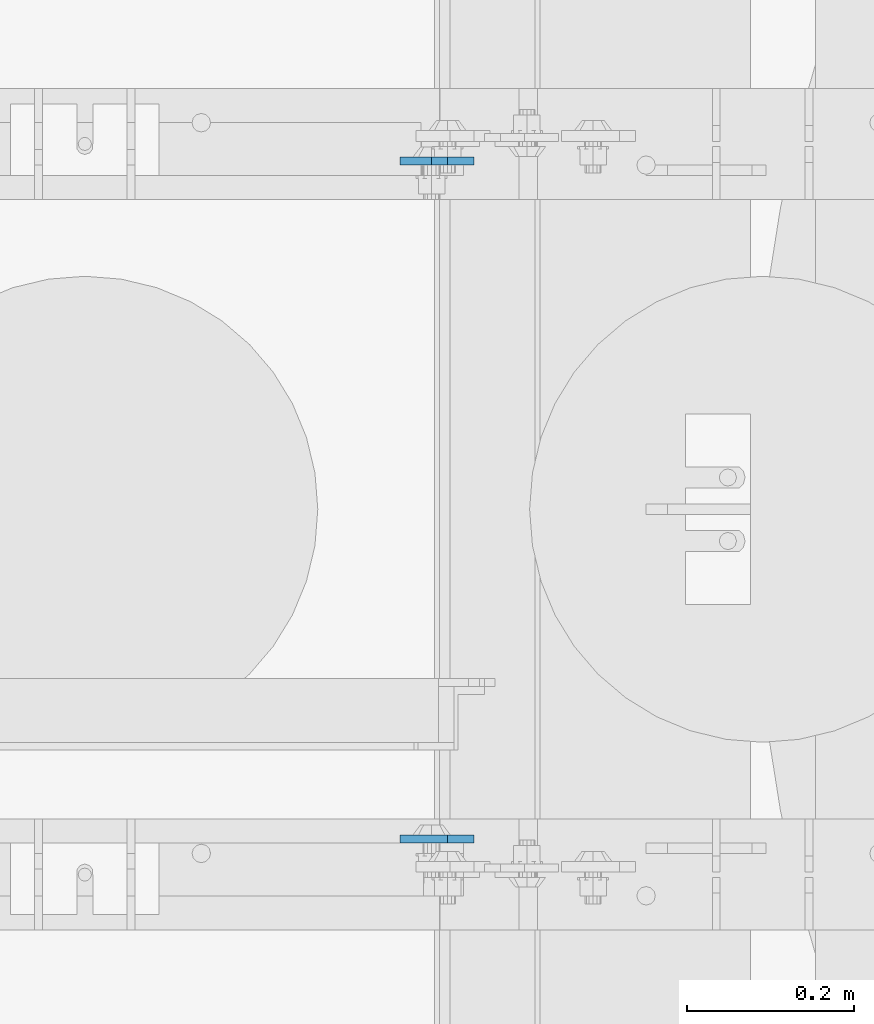
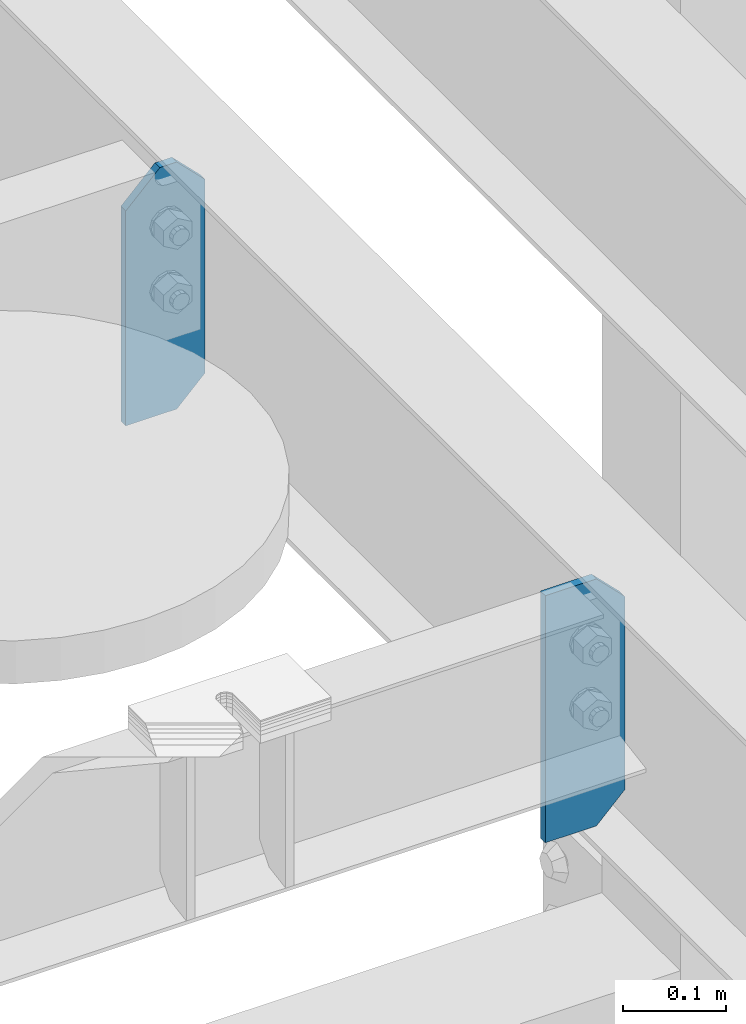
# One storey, part 1759 of 1876: 2 plates, 1 element without a shape of its own.
"""IFC2X3 building model written with IfcOpenShell, lengths in millimetres."""

import ifcopenshell
import ifcopenshell.guid

model = None  # the IFC model being written
_history = None  # IfcOwnerHistory: only IFC2X3 demands one
_inside = {}  # id of a spatial element -> (the spatial element, [elements in it])
_under = {}  # id of a project, library or spatial element -> (it, [spatial elements below it])
_declared = {}  # id of a project -> (the project, [libraries it declares])
_typed = {}  # id of a type object -> (the type object, [elements of that type])
_made_of = {}  # id of a material, layer set ... -> (it, [elements and type objects made of it])


def new_model(schema):
    """Start an empty IFC model of exactly this schema.

    Asked for "IFC4X3", IfcOpenShell would pick the latest addendum, in which some entities
    have other attributes; the version numbers below select the first issue.
    IFC2X3 requires an IfcOwnerHistory on every rooted entity: one is made here for all.
    """
    global model, _history
    if schema == "IFC4X3":
        model = ifcopenshell.file(schema_version=(4, 3, 0, 0))
    else:
        model = ifcopenshell.file(schema=schema)
    _inside.clear()
    _under.clear()
    _declared.clear()
    _typed.clear()
    _made_of.clear()
    _history = None
    if model.schema == "IFC2X3":
        org = make("IfcOrganization", Name="unknown")
        user = make(
            "IfcPersonAndOrganization",
            ThePerson=make("IfcPerson", FamilyName="unknown"),
            TheOrganization=org,
        )
        app = make(
            "IfcApplication",
            ApplicationDeveloper=org,
            Version="unknown",
            ApplicationFullName="unknown",
            ApplicationIdentifier="unknown",
        )
        _history = make(
            "IfcOwnerHistory",
            OwningUser=user,
            OwningApplication=app,
            ChangeAction="ADDED",
            CreationDate=0,
        )
    return model


def make(cls, **values):
    """One entity of the class cls with the attributes given. An attribute that is None is left unset."""
    return model.create_entity(
        cls, **{name: value for name, value in values.items() if value is not None}
    )


def rooted(cls, **values):
    """An entity with a GlobalId (a new one), such as an element, a storey or a relation."""
    return make(cls, GlobalId=ifcopenshell.guid.new(), OwnerHistory=_history, **values)


def si_unit(unit_type, name, prefix=None):
    """IfcSIUnit, for example si_unit("LENGTHUNIT", "METRE", prefix="MILLI")."""
    return make("IfcSIUnit", UnitType=unit_type, Prefix=prefix, Name=name)


def assignment(units):
    """IfcUnitAssignment: the units of a project."""
    return None if units is None else make("IfcUnitAssignment", Units=units)


def point(xyz):
    """IfcCartesianPoint."""
    return None if xyz is None else make("IfcCartesianPoint", Coordinates=xyz)


def direction(xyz):
    """IfcDirection."""
    return None if xyz is None else make("IfcDirection", DirectionRatios=xyz)


def frame(location, z_axis=None, x_axis=None):
    """IfcAxis2Placement3D, a coordinate frame: its origin and axes. An axis left out is left unset."""
    return make(
        "IfcAxis2Placement3D",
        Location=point(location),
        Axis=direction(z_axis),
        RefDirection=direction(x_axis),
    )


def origin_with_axes():
    """The frame at (0, 0, 0) with the z axis (0, 0, 1) and the x axis (1, 0, 0) written out."""
    return frame((0.0, 0.0, 0.0), z_axis=(0.0, 0.0, 1.0), x_axis=(1.0, 0.0, 0.0))


def place(relative_to, where):
    """IfcLocalPlacement: puts the frame where relative to a parent placement (None: the world)."""
    return make(
        "IfcLocalPlacement", PlacementRelTo=relative_to, RelativePlacement=where
    )


def context(
    kind, dimensions, precision=None, world=None, true_north=None, identifier=None
):
    """IfcGeometricRepresentationContext, for example the 3D "Model" context."""
    return make(
        "IfcGeometricRepresentationContext",
        ContextIdentifier=identifier,
        ContextType=kind,
        CoordinateSpaceDimension=dimensions,
        Precision=precision,
        WorldCoordinateSystem=world,
        TrueNorth=true_north,
    )


def subcontext(parent, identifier, kind, view, scale=None):
    """IfcGeometricRepresentationSubContext, for example "Body" below "Model"."""
    return make(
        "IfcGeometricRepresentationSubContext",
        ContextIdentifier=identifier,
        ContextType=kind,
        ParentContext=parent,
        TargetScale=scale,
        TargetView=view,
    )


def project(units=None, contexts=None):
    """IfcProject with its units and contexts."""
    return rooted(
        "IfcProject",
        Name="project",
        RepresentationContexts=contexts,
        UnitsInContext=assignment(units),
    )


def spatial(cls, under=None, at=None, **own):
    """A site, building, storey or space (cls), placed at a placement, below another one or the project."""
    s = rooted(cls, ObjectPlacement=at, **own)
    if under is not None:
        _under.setdefault(under.id(), (under, []))[1].append(s)
    return s


def faces_of(points, faces, orient=None, outer=None):
    """IfcFace entities. A face is a list of loops; a loop is a list of indices into points, from 0.

    orient and outer hold one flag for each loop. By default every Orientation is true, the
    first loop of a face is its IfcFaceOuterBound and the others are IfcFaceBound.
    """
    made = []
    for i, loops in enumerate(faces):
        bounds = []
        for j, loop in enumerate(loops):
            is_outer = j == 0 if outer is None else outer[i][j]
            bounds.append(
                make(
                    "IfcFaceOuterBound" if is_outer else "IfcFaceBound",
                    Bound=make("IfcPolyLoop", Polygon=[points[k] for k in loop]),
                    Orientation=True if orient is None else orient[i][j],
                )
            )
        made.append(make("IfcFace", Bounds=bounds))
    return made


def faceted_brep(points, faces, orient=None, outer=None, voids=None):
    """IfcFacetedBrep: a solid bounded by flat faces; with voids (closed shells), ...WithVoids."""
    shared = [point(p) for p in points]
    hull = make("IfcClosedShell", CfsFaces=faces_of(shared, faces, orient, outer))
    if voids is None:
        return make("IfcFacetedBrep", Outer=hull)
    return make(
        "IfcFacetedBrepWithVoids",
        Outer=hull,
        Voids=[
            make(cls, CfsFaces=faces_of(shared, fs, o, b)) for cls, fs, o, b in voids
        ],
    )


def shape(context_of_items, identifier, shape_type, items):
    """IfcShapeRepresentation: the items that make up one representation, for example the "Body"."""
    return make(
        "IfcShapeRepresentation",
        ContextOfItems=context_of_items,
        RepresentationIdentifier=identifier,
        RepresentationType=shape_type,
        Items=items,
    )


def material(Name=None, Category=None):
    """IfcMaterial."""
    return make("IfcMaterial", Name=Name, Category=Category)


def made_of(thing, what):
    """Note that an element or type object is made of a material, layer set ...; save() writes the relation."""
    if what is not None:
        _made_of.setdefault(what.id(), (what, []))[1].append(thing)
    return thing


def type_object(cls, material=None, **own):
    """A type object (cls), such as IfcWallType, which elements share."""
    return made_of(rooted(cls, **own), material)


def element(
    cls,
    number,
    at=None,
    inside=None,
    cuts=None,
    type_object=None,
    material=None,
    context=None,
    identifier="Body",
    shape_type=None,
    held_by="IfcProductDefinitionShape",
    body=None,
    shapes=None,
    **own,
):
    """One element of the class cls, such as IfcWall. Its Tag is "e" and its number.

    at: its placement. inside: the storey or other place that contains it. cuts: it is an
    opening in that element (IfcRelVoidsElement). A single representation is given by context,
    identifier, shape_type and body (its items); several are given by shapes. held_by: the class
    of the entity that holds the representations. save() writes the other relations.
    """
    e = rooted(cls, Tag="e%d" % number, ObjectPlacement=at, **own)
    if body is not None:
        shapes = [shape(context, identifier, shape_type, body)]
    if shapes is not None:
        e.Representation = make(held_by, Representations=shapes)
    if inside is not None:
        _inside.setdefault(inside.id(), (inside, []))[1].append(e)
    if cuts is not None:
        rooted(
            "IfcRelVoidsElement", RelatingBuildingElement=cuts, RelatedOpeningElement=e
        )
    if type_object is not None:
        _typed.setdefault(type_object.id(), (type_object, []))[1].append(e)
    return made_of(e, material)


def aggregate(whole, parts):
    """IfcRelAggregates: a whole, such as a stair, and the parts it consists of."""
    return rooted("IfcRelAggregates", RelatingObject=whole, RelatedObjects=parts)


def save(model, path):
    """Write the relations noted so far, then the file.

    IfcRelAggregates (storeys below a building ...), IfcRelContainedInSpatialStructure (elements
    in a storey), IfcRelDefinesByType, IfcRelAssociatesMaterial and IfcRelDeclares: one each for
    every whole, place, type object, material and project.
    """
    for whole, parts in _under.values():
        aggregate(whole, parts)
    for where, things in _inside.values():
        rooted(
            "IfcRelContainedInSpatialStructure",
            RelatedElements=things,
            RelatingStructure=where,
        )
    for kind, things in _typed.values():
        rooted("IfcRelDefinesByType", RelatedObjects=things, RelatingType=kind)
    for what, things in _made_of.values():
        rooted("IfcRelAssociatesMaterial", RelatedObjects=things, RelatingMaterial=what)
    for by, libraries in _declared.values():
        rooted("IfcRelDeclares", RelatingContext=by, RelatedDefinitions=libraries)
    model.write(path)


model = new_model("IFC2X3")

# Units and contexts
model_context = context("Model", 3, precision=1e-05, world=origin_with_axes())
body_context = subcontext(model_context, "Body", "Model", "MODEL_VIEW")
ifc_project = project(units=[si_unit("LENGTHUNIT", "METRE", prefix="MILLI"), si_unit("AREAUNIT", "SQUARE_METRE"), si_unit("VOLUMEUNIT", "CUBIC_METRE"), si_unit("MASSUNIT", "GRAM", prefix="KILO"), si_unit("TIMEUNIT", "SECOND"), si_unit("PLANEANGLEUNIT", "RADIAN"), si_unit("SOLIDANGLEUNIT", "STERADIAN"), si_unit("THERMODYNAMICTEMPERATUREUNIT", "DEGREE_CELSIUS"), si_unit("LUMINOUSINTENSITYUNIT", "LUMEN")], contexts=[model_context])

# Site, building, storey
site_placement = place(None, origin_with_axes())
site = spatial("IfcSite", under=ifc_project, at=site_placement, CompositionType="ELEMENT")
building_placement = place(site_placement, origin_with_axes())
building = spatial("IfcBuilding", under=site, at=building_placement, Name="Undefined", CompositionType="ELEMENT")
storey_placement = place(building_placement, origin_with_axes())
storey = spatial("IfcBuildingStorey", under=building, at=storey_placement, Name="Undefined", CompositionType="ELEMENT", Elevation=0.0)

# Assembly, plates
assembly_placement = place(storey_placement, origin_with_axes())
assembly = element("IfcElementAssembly", 1, at=assembly_placement, inside=storey, Name="BEAM", AssemblyPlace="NOTDEFINED", PredefinedType="RIGID_FRAME")
ifc_material = material(Name="STEEL/A36")
plate_type = type_object("IfcPlateType", PredefinedType="NOTDEFINED")
plate_1_placement = place(assembly_placement, frame((923.925, 11085.5129999161, 17684.75), z_axis=(0.0, 0.0, 1.0), x_axis=(-1.0, 0.0, 0.0)))
plate_1 = element("IfcPlate", 2, at=plate_1_placement, type_object=plate_type, material=ifc_material, Name="PLATE", context=body_context, shape_type="Brep", body=[
    faceted_brep([(-9.76996261670138e-14, -4.76250000000073, 31.75), (0.0, -4.76250000000073, 260.350006103516), (0.0, 4.76250000000073, 260.350006103516), (-9.76996261670138e-14, 4.76250000000073, 31.75), (31.75, -4.76250000000073, 292.100006103516), (31.75, 4.76250000000073, 292.100006103516), (88.9000015258789, -4.76249999999982, 292.100006103516), (88.9000015258789, 4.76249999999982, 292.100006103516), (88.9000015258789, -4.76249999999982, 0.0), (88.9000015258789, 4.76249999999982, 0.0), (31.75, -4.76250000000073, 0.0), (31.75, 4.76250000000073, 0.0)], [[[0, 1, 2, 3]], [[1, 4, 5, 2]], [[4, 6, 7, 5]], [[6, 8, 9, 7]], [[8, 10, 11, 9]], [[10, 0, 3, 11]], [[5, 7, 9, 11, 3, 2]], [[10, 8, 6, 4, 1, 0]]]),
])
plate_2_placement = place(assembly_placement, frame((923.925, 11898.3102777481, 17684.75), z_axis=(0.0, 0.0, 1.0), x_axis=(-1.0, 0.0, 0.0)))
plate_2 = element("IfcPlate", 3, at=plate_2_placement, type_object=plate_type, material=ifc_material, Name="PLATE", context=body_context, shape_type="Brep", body=[
    faceted_brep([(-9.76996261670138e-14, -4.76250000000073, 31.75), (0.0, -4.76250000000073, 260.350006103516), (0.0, 4.76250000000073, 260.350006103516), (-9.76996261670138e-14, 4.76250000000073, 31.75), (31.75, -4.76250000000073, 292.100006103516), (31.75, 4.76250000000073, 292.100006103516), (50.8000030517578, -4.76250000000073, 292.100006103516), (50.8000030517578, 4.76250000000073, 292.100006103516), (88.9000015258789, -4.76250000000073, 254.000007629395), (88.9000015258789, 4.76250000000073, 254.000007629395), (88.9000015258789, -4.76249999999982, 0.0), (88.9000015258789, 4.76249999999982, 0.0), (31.75, -4.76250000000073, 0.0), (31.75, 4.76250000000073, 0.0)], [[[0, 1, 2, 3]], [[1, 4, 5, 2]], [[4, 6, 7, 5]], [[6, 8, 9, 7]], [[8, 10, 11, 9]], [[10, 12, 13, 11]], [[12, 0, 3, 13]], [[5, 7, 9, 11, 13, 3, 2]], [[12, 10, 8, 6, 4, 1, 0]]]),
])
aggregate(assembly, [plate_1, plate_2])

save(model, "model.ifc")
